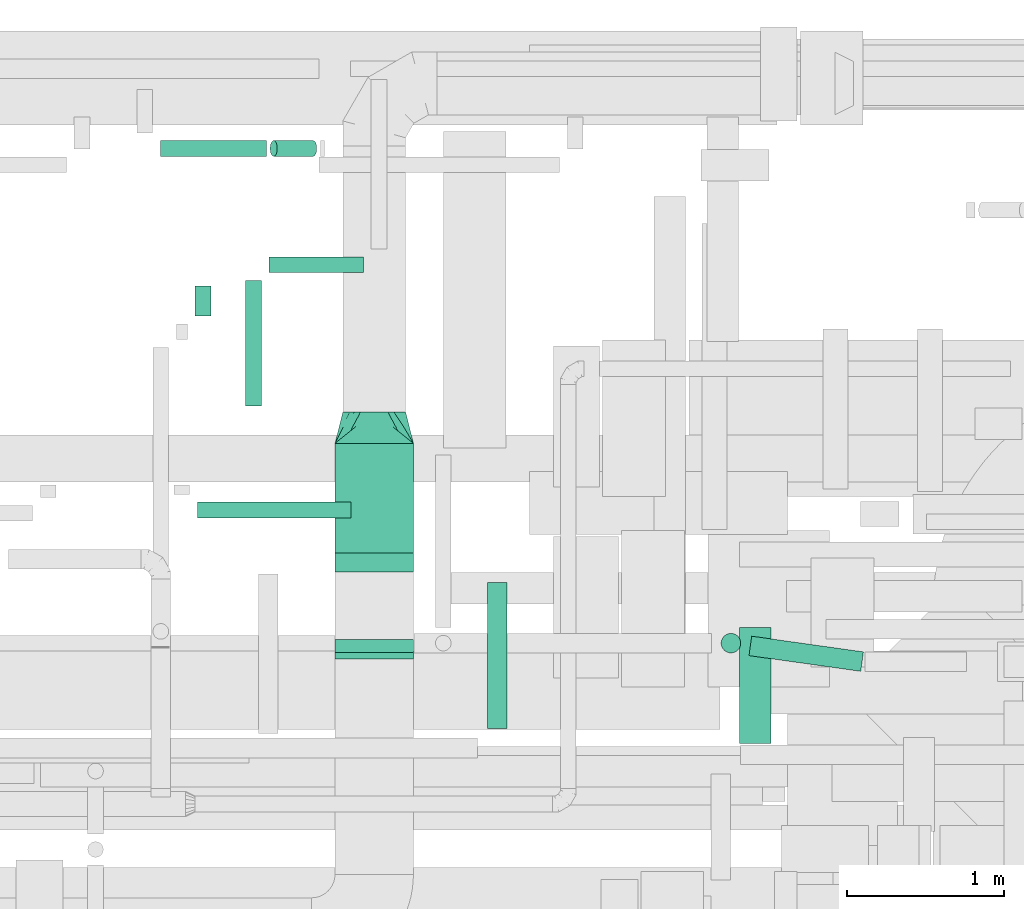
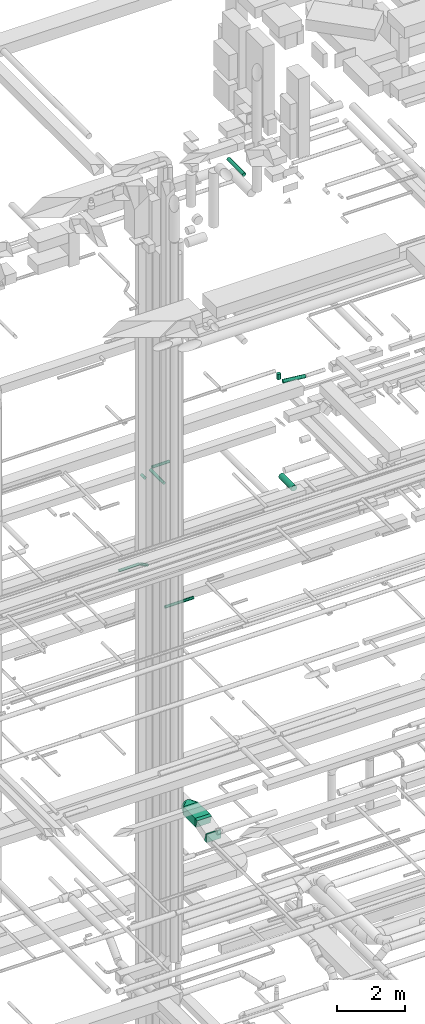
# One storey, part 157 of 337: 11 flow segments, 3 flow fittings.
"""IFC2X3 building model written with IfcOpenShell, lengths in millimetres."""

from ifc_helpers import new_model, entity, si_unit, converted_unit, derived_unit, direction, frame, frame_2d, origin, origin_2d_with_axis, place, context, subcontext, project, spatial, polyline, circle_curve, parameter, trimmed, segment, composite_curve, rectangle, circle, outline, extrude, faceted_brep, source, transform, mapped, material, type_object, type_shapes, element, save


model = new_model("IFC2X3")

# Units and contexts
model_context = context("Model", 3, precision=0.01, world=origin(), true_north=direction((6.12303176911189e-17, 1.0)))
body_context = subcontext(model_context, "Body", "Model", "MODEL_VIEW")
ifc_project = project(units=[si_unit("LENGTHUNIT", "METRE", prefix="MILLI"), si_unit("AREAUNIT", "SQUARE_METRE"), si_unit("VOLUMEUNIT", "CUBIC_METRE"), converted_unit("PLANEANGLEUNIT", "DEGREE", entity("IfcRatioMeasure", 0.0174532925199433), si_unit("PLANEANGLEUNIT", "RADIAN"), dimensions=[0, 0, 0, 0, 0, 0, 0]), si_unit("MASSUNIT", "GRAM", prefix="KILO"), derived_unit("MASSDENSITYUNIT", [(si_unit("MASSUNIT", "GRAM", prefix="KILO"), 1), (si_unit("LENGTHUNIT", "METRE"), -3)]), derived_unit("MOMENTOFINERTIAUNIT", [(si_unit("LENGTHUNIT", "METRE"), 4)]), si_unit("TIMEUNIT", "SECOND"), si_unit("FREQUENCYUNIT", "HERTZ"), si_unit("THERMODYNAMICTEMPERATUREUNIT", "DEGREE_CELSIUS"), derived_unit("THERMALTRANSMITTANCEUNIT", [(si_unit("MASSUNIT", "GRAM", prefix="KILO"), 1), (si_unit("THERMODYNAMICTEMPERATUREUNIT", "KELVIN"), -1), (si_unit("TIMEUNIT", "SECOND"), -3)]), derived_unit("VOLUMETRICFLOWRATEUNIT", [(si_unit("LENGTHUNIT", "METRE"), 3), (si_unit("TIMEUNIT", "SECOND"), -1)]), derived_unit("MASSFLOWRATEUNIT", [(si_unit("MASSUNIT", "GRAM", prefix="KILO"), 1), (si_unit("TIMEUNIT", "SECOND"), -1)]), derived_unit("ROTATIONALFREQUENCYUNIT", [(si_unit("TIMEUNIT", "SECOND"), -1)]), si_unit("ELECTRICCURRENTUNIT", "AMPERE"), si_unit("ELECTRICVOLTAGEUNIT", "VOLT"), si_unit("POWERUNIT", "WATT"), si_unit("FORCEUNIT", "NEWTON", prefix="KILO"), si_unit("ILLUMINANCEUNIT", "LUX"), si_unit("LUMINOUSFLUXUNIT", "LUMEN"), si_unit("LUMINOUSINTENSITYUNIT", "CANDELA"), derived_unit("USERDEFINED", [(si_unit("MASSUNIT", "GRAM", prefix="KILO"), -1), (si_unit("LENGTHUNIT", "METRE"), -2), (si_unit("TIMEUNIT", "SECOND"), 3), (si_unit("LUMINOUSFLUXUNIT", "LUMEN"), 1)]), derived_unit("LINEARVELOCITYUNIT", [(si_unit("LENGTHUNIT", "METRE"), 1), (si_unit("TIMEUNIT", "SECOND"), -1)]), si_unit("PRESSUREUNIT", "PASCAL"), derived_unit("USERDEFINED", [(si_unit("LENGTHUNIT", "METRE"), -2), (si_unit("MASSUNIT", "GRAM", prefix="KILO"), 1), (si_unit("TIMEUNIT", "SECOND"), -2)]), derived_unit("LINEARFORCEUNIT", [(si_unit("MASSUNIT", "GRAM", prefix="KILO"), 1), (si_unit("LENGTHUNIT", "METRE"), 1), (si_unit("TIMEUNIT", "SECOND"), -2), (si_unit("LENGTHUNIT", "METRE"), -1)]), derived_unit("PLANARFORCEUNIT", [(si_unit("MASSUNIT", "GRAM", prefix="KILO"), 1), (si_unit("LENGTHUNIT", "METRE"), 1), (si_unit("TIMEUNIT", "SECOND"), -2), (si_unit("LENGTHUNIT", "METRE"), -2)])], contexts=[model_context])

# Site, building, storey
site_placement = place(None, origin())
site = spatial("IfcSite", under=ifc_project, at=site_placement, CompositionType="ELEMENT")
building_placement = place(site_placement, origin())
building = spatial("IfcBuilding", under=site, at=building_placement, CompositionType="ELEMENT")
storey_placement = place(building_placement, origin())
storey = spatial("IfcBuildingStorey", under=building, at=storey_placement, CompositionType="ELEMENT", Elevation=0.0)

# Flow segments
duct_segment_type_1 = type_object("IfcDuctSegmentType", PredefinedType="NOTDEFINED")
flow_segment_1_placement = place(storey_placement, frame((35072.98, 16826.79, 3320.0)))
element("IfcFlowSegment", 1, at=flow_segment_1_placement, inside=storey, type_object=duct_segment_type_1, context=body_context, shape_type="SweptSolid", body=[
    extrude(rectangle(XDim=697.601254875567, YDim=499.999999999999, at=origin_2d_with_axis()), frame((250.0, 348.8, 0.0), z_axis=(0.0, 0.0, 1.0), x_axis=(0.0, 1.0, 0.0)), (0.0, 0.0, 1.0), 300.0),
])
duct_segment_type_2 = type_object("IfcDuctSegmentType", PredefinedType="NOTDEFINED")
flow_segment_2_placement = place(storey_placement, frame((33960.89, 19353.19, 11348.4)))
element("IfcFlowSegment", 2, at=flow_segment_2_placement, inside=storey, type_object=duct_segment_type_2, context=body_context, shape_type="SweptSolid", body=[
    extrude(circle(Radius=50.0, at=origin_2d_with_axis()), frame((0.0, 51.6, 51.6), z_axis=(1.0, 0.0, 0.0), x_axis=(0.0, 1.0, 0.0)), (0.0, 0.0, 1.0), 675.992124092023),
])
flow_segment_3_placement = place(storey_placement, frame((34657.98, 19353.19, 11214.75)))
element("IfcFlowSegment", 3, at=flow_segment_3_placement, inside=storey, type_object=duct_segment_type_2, context=body_context, shape_type="SweptSolid", body=[
    extrude(circle(Radius=50.0, at=origin_2d_with_axis()), frame((275.9, 51.6, 46.15), z_axis=(-0.891006524188367, 0.0, 0.453990499739549), x_axis=(0.0, -1.0, 0.0)), (0.0, 0.0, 1.0), 282.387637870403),
])
flow_segment_4_placement = place(storey_placement, frame((34180.23, 18335.5, 15248.4)))
element("IfcFlowSegment", 4, at=flow_segment_4_placement, inside=storey, type_object=duct_segment_type_2, context=body_context, shape_type="SweptSolid", body=[
    extrude(circle(Radius=50.0, at=origin_2d_with_axis()), frame((51.6, 0.0, 51.6), z_axis=(4.31236400063712e-06, 1.0, 0.0), x_axis=(1.0, -4.31236400063712e-06, 0.0)), (0.0, 0.0, 1.0), 192.077076428696),
])
flow_segment_5_placement = place(storey_placement, frame((34195.41, 17047.64, 11348.4)))
element("IfcFlowSegment", 5, at=flow_segment_5_placement, inside=storey, type_object=duct_segment_type_2, context=body_context, shape_type="SweptSolid", body=[
    extrude(circle(Radius=50.0, at=origin_2d_with_axis()), frame((0.0, 51.6, 51.6), z_axis=(1.0, 0.0, 0.0), x_axis=(0.0, -1.0, 0.0)), (0.0, 0.0, 1.0), 980.000000000003),
])
flow_segment_6_placement = place(storey_placement, frame((37711.14, 16069.24, 18785.9)))
element("IfcFlowSegment", 6, at=flow_segment_6_placement, inside=storey, type_object=duct_segment_type_2, context=body_context, shape_type="SweptSolid", body=[
    extrude(circle(Radius=62.5, at=origin_2d_with_axis()), frame((722.55, 63.49, 64.1), z_axis=(-0.990245475749996, 0.139333763878914, 0.0), x_axis=(-0.139333763878914, -0.990245475749996, 0.0)), (0.0, 0.0, 1.0), 719.264066349602),
])
flow_segment_7_placement = place(storey_placement, frame((37533.57, 16186.26, 18975.0)))
element("IfcFlowSegment", 7, at=flow_segment_7_placement, inside=storey, type_object=duct_segment_type_2, context=body_context, shape_type="SweptSolid", body=[
    extrude(circle(Radius=62.5, at=origin_2d_with_axis()), frame((64.1, 64.1, 0.0), z_axis=(0.0, 0.0, 1.0), x_axis=(0.0, -1.0, 0.0)), (0.0, 0.0, 1.0), 200.000000000013),
])
flow_segment_8_placement = place(storey_placement, frame((34653.69, 18612.29, 15298.4)))
element("IfcFlowSegment", 8, at=flow_segment_8_placement, inside=storey, type_object=duct_segment_type_2, context=body_context, shape_type="SweptSolid", body=[
    extrude(circle(Radius=50.0, at=origin_2d_with_axis()), frame((0.0, 51.6, 51.6), z_axis=(1.0, 0.0, 0.0), x_axis=(0.0, 1.0, 0.0)), (0.0, 0.0, 1.0), 600.000000000011),
])
flow_segment_9_placement = place(storey_placement, frame((34502.09, 17763.88, 15298.4)))
element("IfcFlowSegment", 9, at=flow_segment_9_placement, inside=storey, type_object=duct_segment_type_2, context=body_context, shape_type="SweptSolid", body=[
    extrude(circle(Radius=50.0, at=origin_2d_with_axis()), frame((51.6, 0.0, 51.6), z_axis=(0.0, 1.0, 0.0), x_axis=(-1.0, 0.0, 0.0)), (0.0, 0.0, 1.0), 800.000000000009),
])
flow_segment_10_placement = place(storey_placement, frame((37650.76, 15610.0, 15248.4)))
element("IfcFlowSegment", 10, at=flow_segment_10_placement, inside=storey, type_object=duct_segment_type_2, context=body_context, shape_type="SweptSolid", body=[
    extrude(circle(Radius=100.0, at=origin_2d_with_axis()), frame((101.6, 0.0, 101.6), z_axis=(0.0, 1.0, 0.0), x_axis=(-1.0, 0.0, 0.0)), (0.0, 0.0, 1.0), 739.999999999849),
])
flow_segment_11_placement = place(storey_placement, frame((36043.95, 15706.99, 27135.9)))
element("IfcFlowSegment", 11, at=flow_segment_11_placement, inside=storey, type_object=duct_segment_type_2, context=body_context, shape_type="SweptSolid", body=[
    extrude(circle(Radius=62.5, at=origin_2d_with_axis()), frame((64.1, 0.0, 64.1), z_axis=(0.0, 1.0, 0.0), x_axis=(1.0, 0.0, 0.0)), (0.0, 0.0, 1.0), 930.910030124729),
])

# Flow fittings
ifc_material = material()
duct_fitting_type_1 = type_object("IfcDuctFittingType", PredefinedType="NOTDEFINED", material=ifc_material)
shared_shape_1 = source(origin(), body_context, "Body", "Brep", [
    faceted_brep([(200.0, 44.5, 194.99), (200.0, 31.87, 196.41), (200.0, 19.23, 197.83), (200.0, 0.0, 200.0), (200.0, -19.23, 197.83), (200.0, -31.87, 196.41), (200.0, -44.5, 194.99), (200.0, -65.64, 187.59), (200.0, -86.78, 180.19), (200.0, -105.74, 168.28), (200.0, -124.7, 156.37), (200.0, -140.53, 140.53), (200.0, -156.37, 124.7), (200.0, -168.28, 105.74), (200.0, -180.19, 86.78), (200.0, -187.59, 65.64), (200.0, -194.99, 44.5), (200.0, -196.41, 31.87), (200.0, -197.83, 19.23), (200.0, -200.0, 0.0), (200.0, -197.83, -19.23), (200.0, -196.41, -31.87), (200.0, -194.99, -44.5), (200.0, -187.59, -65.64), (200.0, -180.19, -86.78), (200.0, -168.28, -105.74), (200.0, -156.37, -124.7), (200.0, -140.53, -140.53), (200.0, -124.7, -156.37), (200.0, -105.74, -168.28), (200.0, -86.78, -180.19), (200.0, -65.64, -187.59), (200.0, -44.5, -194.99), (200.0, -31.87, -196.41), (200.0, -19.23, -197.83), (200.0, 0.0, -200.0), (200.0, 19.23, -197.83), (200.0, 31.87, -196.41), (200.0, 44.5, -194.99), (200.0, 65.64, -187.59), (200.0, 86.78, -180.19), (200.0, 105.74, -168.28), (200.0, 124.7, -156.37), (200.0, 140.53, -140.53), (200.0, 156.37, -124.7), (200.0, 168.28, -105.74), (200.0, 180.19, -86.78), (200.0, 187.59, -65.64), (200.0, 194.99, -44.5), (200.0, 196.41, -31.87), (200.0, 197.83, -19.23), (200.0, 200.0, 0.0), (200.0, 197.83, 19.23), (200.0, 196.41, 31.87), (200.0, 194.99, 44.5), (200.0, 187.59, 65.64), (200.0, 180.19, 86.78), (200.0, 168.28, 105.74), (200.0, 156.37, 124.7), (200.0, 140.53, 140.53), (200.0, 124.7, 156.37), (200.0, 105.74, 168.28), (200.0, 86.78, 180.19), (200.0, 65.64, 187.59), (0.0, -250.0, 150.0), (0.0, 250.0, 150.0), (0.0, 250.0, -150.0), (0.0, -250.0, -150.0), (128.09, -217.98, 53.94), (104.11, -223.97, 71.91), (78.09, -152.39, 169.52), (52.06, -184.93, 163.01), (152.06, -211.99, 35.96), (164.04, -208.99, 26.97), (176.03, -205.99, 17.98), (128.09, -89.89, 182.02), (164.04, -44.95, 191.01), (152.06, -59.93, 188.01), (176.03, -29.96, 194.01), (26.03, -243.49, 130.48), (100.0, -191.3, 149.86), (26.03, -217.46, 156.51), (52.06, -236.99, 110.96), (104.11, -119.86, 176.03), (78.09, -230.48, 91.44), (26.03, -243.49, -130.48), (52.06, -236.99, -110.96), (78.09, -230.48, -91.44), (104.11, -223.97, -71.91), (128.09, -217.98, -53.94), (152.06, -211.99, -35.96), (164.04, -208.99, -26.97), (176.03, -205.99, -17.98), (128.09, -89.89, -182.02), (104.11, -119.86, -176.03), (152.06, -59.93, -188.01), (164.04, -44.95, -191.01), (176.03, -29.96, -194.01), (26.03, -217.46, -156.51), (100.0, -199.86, -141.3), (52.06, -184.93, -163.01), (78.09, -152.39, -169.52), (26.03, 217.46, -156.51), (52.06, 184.93, -163.01), (78.09, 152.39, -169.52), (104.11, 119.86, -176.03), (128.09, 89.89, -182.02), (152.06, 59.93, -188.01), (164.04, 44.95, -191.01), (176.03, 29.96, -194.01), (128.09, 217.98, -53.94), (104.11, 223.97, -71.91), (152.06, 211.99, -35.96), (164.04, 208.99, -26.97), (176.03, 205.99, -17.98), (26.03, 243.49, -130.48), (100.0, 191.3, -149.86), (52.06, 236.99, -110.96), (78.09, 230.48, -91.44), (26.03, 243.49, 130.48), (52.06, 236.99, 110.96), (78.09, 230.48, 91.44), (104.11, 223.97, 71.91), (128.09, 217.98, 53.94), (152.06, 211.99, 35.96), (164.04, 208.99, 26.97), (176.03, 205.99, 17.98), (128.09, 89.89, 182.02), (104.11, 119.86, 176.03), (152.06, 59.93, 188.01), (164.04, 44.95, 191.01), (176.03, 29.96, 194.01), (26.03, 217.46, 156.51), (100.0, 199.86, 141.3), (52.06, 184.93, 163.01), (78.09, 152.39, 169.52)], [[[0, 1, 2, 3, 4, 5, 6, 7, 8, 9, 10, 11, 12, 13, 14, 15, 16, 17, 18, 19, 20, 21, 22, 23, 24, 25, 26, 27, 28, 29, 30, 31, 32, 33, 34, 35, 36, 37, 38, 39, 40, 41, 42, 43, 44, 45, 46, 47, 48, 49, 50, 51, 52, 53, 54, 55, 56, 57, 58, 59, 60, 61, 62, 63]], [[64, 65, 66, 67]], [[68, 15, 69]], [[9, 70, 71]], [[16, 68, 72, 73, 74, 19, 18, 17]], [[6, 75, 7]], [[76, 77, 75, 6, 5, 4, 3, 78]], [[79, 12, 80]], [[80, 12, 11, 10]], [[10, 71, 81]], [[79, 82, 12]], [[8, 70, 9]], [[69, 15, 14]], [[83, 8, 7]], [[83, 7, 75]], [[68, 16, 15]], [[8, 83, 70]], [[84, 13, 82]], [[84, 69, 14]], [[64, 80, 81]], [[81, 80, 10]], [[79, 80, 64]], [[71, 10, 9]], [[13, 84, 14]], [[13, 12, 82]], [[74, 73, 72, 68, 69, 84, 82, 79, 64, 67, 85, 86, 87, 88, 89, 90, 91, 92, 19]], [[93, 31, 94]], [[25, 87, 86]], [[32, 93, 95, 96, 97, 35, 34, 33]], [[22, 89, 23]], [[91, 90, 89, 22, 21, 20, 19, 92]], [[98, 28, 99]], [[99, 28, 27, 26]], [[26, 86, 85]], [[98, 100, 28]], [[24, 87, 25]], [[94, 31, 30]], [[88, 24, 23]], [[88, 23, 89]], [[93, 32, 31]], [[24, 88, 87]], [[101, 29, 100]], [[101, 94, 30]], [[67, 99, 85]], [[85, 99, 26]], [[98, 99, 67]], [[86, 26, 25]], [[29, 101, 30]], [[29, 28, 100]], [[97, 96, 95, 93, 94, 101, 100, 98, 67, 66, 102, 103, 104, 105, 106, 107, 108, 109, 35]], [[110, 47, 111]], [[41, 104, 103]], [[48, 110, 112, 113, 114, 51, 50, 49]], [[38, 106, 39]], [[108, 107, 106, 38, 37, 36, 35, 109]], [[115, 44, 116]], [[116, 44, 43, 42]], [[42, 103, 102]], [[115, 117, 44]], [[40, 104, 41]], [[111, 47, 46]], [[105, 40, 39]], [[105, 39, 106]], [[110, 48, 47]], [[40, 105, 104]], [[118, 45, 117]], [[118, 111, 46]], [[66, 116, 102]], [[102, 116, 42]], [[115, 116, 66]], [[103, 42, 41]], [[45, 118, 46]], [[45, 44, 117]], [[66, 65, 119, 120, 121, 122, 123, 124, 125, 126, 51, 114, 113, 112, 110, 111, 118, 117, 115]], [[127, 63, 128]], [[57, 121, 120]], [[0, 127, 129, 130, 131, 3, 2, 1]], [[54, 123, 55]], [[125, 124, 123, 54, 53, 52, 51, 126]], [[132, 60, 133]], [[133, 60, 59, 58]], [[58, 120, 119]], [[132, 134, 60]], [[56, 121, 57]], [[128, 63, 62]], [[122, 56, 55]], [[122, 55, 123]], [[127, 0, 63]], [[56, 122, 121]], [[135, 61, 134]], [[135, 128, 62]], [[65, 133, 119]], [[119, 133, 58]], [[132, 133, 65]], [[120, 58, 57]], [[61, 135, 62]], [[61, 60, 134]], [[65, 64, 81, 71, 70, 83, 75, 77, 76, 78, 3, 131, 130, 129, 127, 128, 135, 134, 132]]]),
])
type_shapes(duct_fitting_type_1, [shared_shape_1])
flow_fitting_placement = place(storey_placement, frame((35322.98, 17524.4, 3470.0), z_axis=(0.0, 0.0, 1.0), x_axis=(0.0, 1.0, 0.0)))
element("IfcFlowFitting", 12, at=flow_fitting_placement, inside=storey, type_object=duct_fitting_type_1, material=ifc_material, context=body_context, shape_type="MappedRepresentation", body=[
    mapped(shared_shape_1, transform((0.0, 0.0, 0.0), scale=1.0)),
])
duct_fitting_type_2 = type_object("IfcDuctFittingType", PredefinedType="NOTDEFINED", material=ifc_material)
shared_shape_2 = source(origin(), body_context, "Body", "SweptSolid", [
    extrude(outline(composite_curve([segment(polyline([(-155.8, -41.32), (144.2, -41.32)]), True, "CONTINUOUS"), segment(trimmed(circle_curve(frame_2d((294.2, -41.32), x_axis=(-0.961311369016316, 0.275464066259061)), 150.0), [parameter(0.0)], [parameter(15.9896713831504)], True, "PARAMETER"), False, "CONTINUOUS"), segment(polyline([(150.0, 0.0), (-138.39, 82.64)]), True, "CONTINUOUS"), segment(trimmed(circle_curve(frame_2d((294.2, -41.32), x_axis=(-0.961311369016316, 0.275464066259061)), 450.0), [parameter(0.0)], [parameter(15.9896713831504)], True, "PARAMETER"), True, "CONTINUOUS")], self_intersect=False)), frame((-0.82, 5.8, -250.0), z_axis=(0.0, 0.0, 1.0), x_axis=(-0.275464066259061, 0.961311369016316, 0.0)), (0.0, 0.0, 1.0), 500.0),
])
type_shapes(duct_fitting_type_2, [shared_shape_2])
for number, where, z_axis, x_axis in (
    (13, (35322.98, 16191.4, 3300.0), (1.0, 0.0, 0.0), (0.0, 1.0, 0.0)),
    (14, (35322.98, 16784.66, 3470.0), (1.0, 0.0, 0.0), (0.0, -1.0, 0.0)),
):
    element("IfcFlowFitting", number, at=place(storey_placement, frame(where, z_axis=z_axis, x_axis=x_axis)), inside=storey, type_object=duct_fitting_type_2, material=ifc_material, context=body_context, shape_type="MappedRepresentation", body=[
        mapped(shared_shape_2, transform((0.0, 0.0, 0.0), scale=1.0)),
    ])

save(model, "model.ifc")
